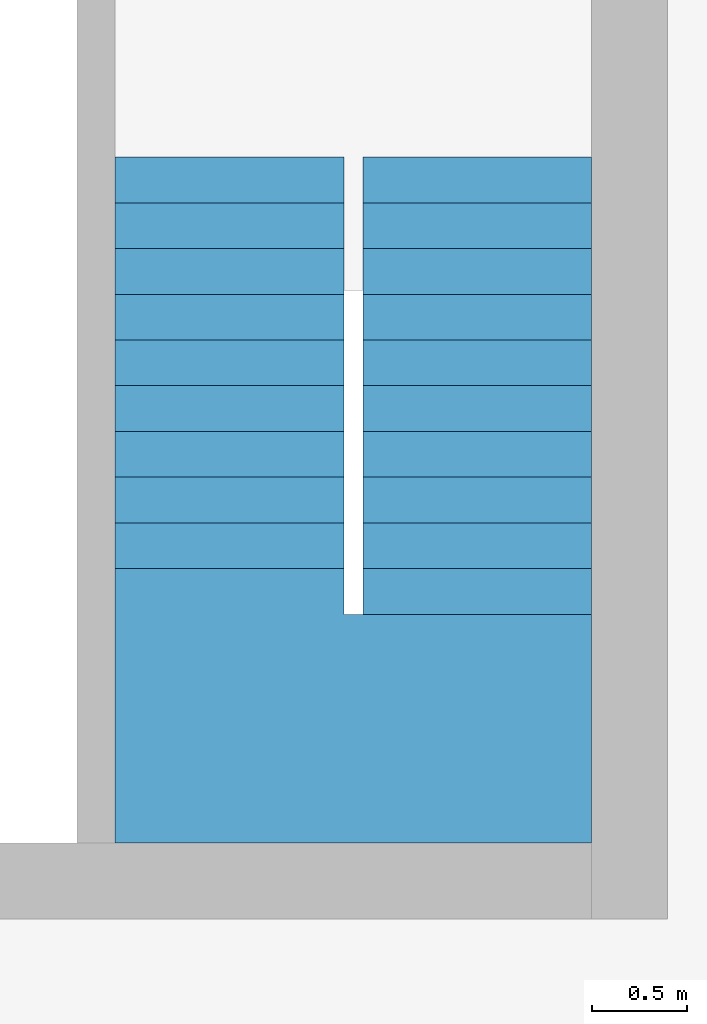
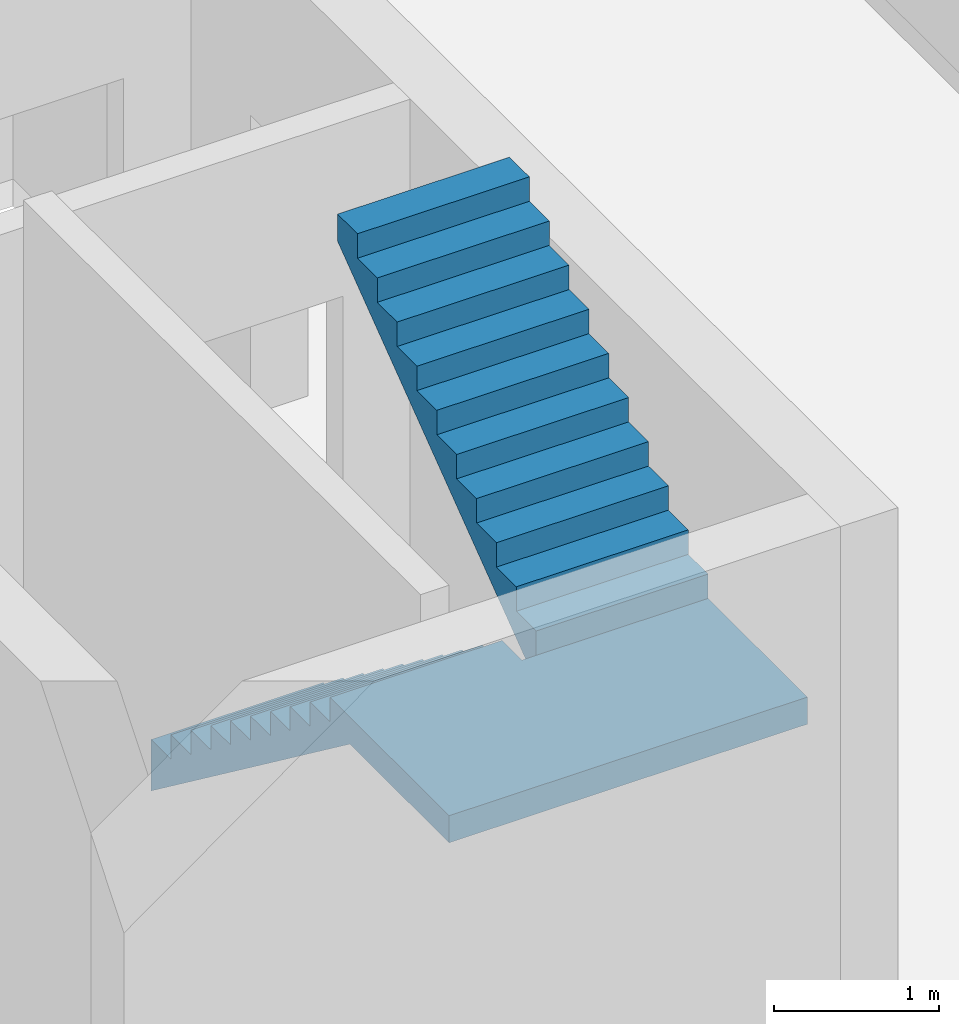
# One storey, part 2 of 4: 1 stair.
"""IFC2X3 building model written with IfcOpenShell, lengths in metres."""

from ifc_helpers import new_model, entity, si_unit, converted_unit, frame, origin, place, context, subcontext, project, spatial, faceted_brep, material, element, save


model = new_model("IFC2X3")

# Units and contexts
model_context = context("Model", 3, precision=1e-05, world=origin())
body_context = subcontext(model_context, "Body", "Model", "MODEL_VIEW")
ifc_project = project(units=[si_unit("LENGTHUNIT", "METRE"), si_unit("AREAUNIT", "SQUARE_METRE"), si_unit("VOLUMEUNIT", "CUBIC_METRE"), si_unit("MASSUNIT", "GRAM", prefix="KILO"), converted_unit("PLANEANGLEUNIT", "DEGREE", entity("IfcPlaneAngleMeasure", 0.0174532925199433), si_unit("PLANEANGLEUNIT", "RADIAN"), dimensions=[0, 0, 0, 0, 0, 0, 0])], contexts=[model_context])

# Site, building, storey
site_placement = place(None, origin())
site = spatial("IfcSite", under=ifc_project, at=site_placement, CompositionType="ELEMENT")
building_placement = place(site_placement, origin())
building = spatial("IfcBuilding", under=site, at=building_placement, CompositionType="ELEMENT")
storey_placement = place(building_placement, frame((0.0, 0.0, 4.9)))
storey = spatial("IfcBuildingStorey", under=building, at=storey_placement, Name="1. Obergeschoss", CompositionType="ELEMENT", Elevation=4.9)

# Stair
ifc_material = material(Name="FT_STB C45")
stair_placement = place(storey_placement, frame((22.5, 5.4, 0.0)))
element("IfcStair", 1, at=stair_placement, inside=storey, material=ifc_material, Name="II", ShapeType="NOTDEFINED", context=body_context, shape_type="Brep", body=[
    faceted_brep([(0.0, 3.6, 0.0), (0.0, 3.36001, 0.18), (1.2, 3.36001, 0.18), (1.2, 3.6, 0.0), (1.2, 3.6, 0.38), (1.2, 3.36001, 0.38), (0.0, 3.36001, 0.38), (0.0, 3.6, 0.38)], [[[0, 1, 2, 3]], [[4, 5, 6, 7]], [[3, 4, 7, 0]], [[0, 7, 6, 1]], [[1, 6, 5, 2]], [[2, 5, 4, 3]]], orient=[[False], [False], [False], [False], [False], [False]]),
    faceted_brep([(0.0, 3.36001, 0.18), (0.0, 3.12002, 0.36), (1.2, 3.12002, 0.36), (1.2, 3.36001, 0.18), (1.2, 3.36001, 0.56), (1.2, 3.12002, 0.56), (0.0, 3.12002, 0.56), (0.0, 3.36001, 0.56)], [[[0, 1, 2, 3]], [[4, 5, 6, 7]], [[3, 4, 7, 0]], [[0, 7, 6, 1]], [[1, 6, 5, 2]], [[2, 5, 4, 3]]], orient=[[False], [False], [False], [False], [False], [False]]),
    faceted_brep([(0.0, 3.12002, 0.36), (0.0, 2.88003, 0.54), (1.2, 2.88003, 0.54), (1.2, 3.12002, 0.36), (1.2, 3.12002, 0.74), (1.2, 2.88003, 0.74), (0.0, 2.88003, 0.74), (0.0, 3.12002, 0.74)], [[[0, 1, 2, 3]], [[4, 5, 6, 7]], [[3, 4, 7, 0]], [[0, 7, 6, 1]], [[1, 6, 5, 2]], [[2, 5, 4, 3]]], orient=[[False], [False], [False], [False], [False], [False]]),
    faceted_brep([(0.0, 2.88003, 0.54), (0.0, 2.64004, 0.72), (1.2, 2.64004, 0.72), (1.2, 2.88003, 0.54), (1.2, 2.88003, 0.92), (1.2, 2.64004, 0.92), (0.0, 2.64004, 0.92), (0.0, 2.88003, 0.92)], [[[0, 1, 2, 3]], [[4, 5, 6, 7]], [[3, 4, 7, 0]], [[0, 7, 6, 1]], [[1, 6, 5, 2]], [[2, 5, 4, 3]]], orient=[[False], [False], [False], [False], [False], [False]]),
    faceted_brep([(0.0, 2.64004, 0.72), (0.0, 2.40005, 0.9), (1.2, 2.40005, 0.9), (1.2, 2.64004, 0.72), (1.2, 2.64004, 1.1), (1.2, 2.40005, 1.1), (0.0, 2.40005, 1.1), (0.0, 2.64004, 1.1)], [[[0, 1, 2, 3]], [[4, 5, 6, 7]], [[3, 4, 7, 0]], [[0, 7, 6, 1]], [[1, 6, 5, 2]], [[2, 5, 4, 3]]], orient=[[False], [False], [False], [False], [False], [False]]),
    faceted_brep([(0.0, 2.40005, 0.9), (0.0, 2.16006, 1.08), (1.2, 2.16006, 1.08), (1.2, 2.40005, 0.9), (1.2, 2.40005, 1.28), (1.2, 2.16006, 1.28), (0.0, 2.16006, 1.28), (0.0, 2.40005, 1.28)], [[[0, 1, 2, 3]], [[4, 5, 6, 7]], [[3, 4, 7, 0]], [[0, 7, 6, 1]], [[1, 6, 5, 2]], [[2, 5, 4, 3]]], orient=[[False], [False], [False], [False], [False], [False]]),
    faceted_brep([(0.0, 2.16006, 1.08), (0.0, 1.92007, 1.26), (1.2, 1.92007, 1.26), (1.2, 2.16006, 1.08), (1.2, 2.16006, 1.46), (1.2, 1.92007, 1.46), (0.0, 1.92007, 1.46), (0.0, 2.16006, 1.46)], [[[0, 1, 2, 3]], [[4, 5, 6, 7]], [[3, 4, 7, 0]], [[0, 7, 6, 1]], [[1, 6, 5, 2]], [[2, 5, 4, 3]]], orient=[[False], [False], [False], [False], [False], [False]]),
    faceted_brep([(0.0, 1.92007, 1.26), (0.0, 1.68008, 1.44), (1.2, 1.68008, 1.44), (1.2, 1.92007, 1.26), (1.2, 1.92007, 1.64), (1.2, 1.68008, 1.64), (0.0, 1.68008, 1.64), (0.0, 1.92007, 1.64)], [[[0, 1, 2, 3]], [[4, 5, 6, 7]], [[3, 4, 7, 0]], [[0, 7, 6, 1]], [[1, 6, 5, 2]], [[2, 5, 4, 3]]], orient=[[False], [False], [False], [False], [False], [False]]),
    faceted_brep([(0.0, 1.68008, 1.44), (0.0, 1.44009, 1.62), (1.2, 1.44009, 1.62), (1.2, 1.68008, 1.44), (1.2, 1.68008, 1.82), (1.2, 1.44009, 1.82), (0.0, 1.44009, 1.82), (0.0, 1.68008, 1.82)], [[[0, 1, 2, 3]], [[4, 5, 6, 7]], [[3, 4, 7, 0]], [[0, 7, 6, 1]], [[1, 6, 5, 2]], [[2, 5, 4, 3]]], orient=[[False], [False], [False], [False], [False], [False]]),
    faceted_brep([(0.0, 1.44009, 1.62), (0.0, 1.2001, 1.8), (1.2, 1.2001, 1.8), (1.2, 1.44009, 1.62), (1.2, 1.44009, 2.0), (1.2, 1.2001, 2.0), (0.0, 1.2001, 2.0), (0.0, 1.44009, 2.0)], [[[0, 1, 2, 3]], [[4, 5, 6, 7]], [[3, 4, 7, 0]], [[0, 7, 6, 1]], [[1, 6, 5, 2]], [[2, 5, 4, 3]]], orient=[[False], [False], [False], [False], [False], [False]]),
    faceted_brep([(1.2, 1.2001, 1.8), (0.0, 1.2001, 1.8), (0.0, 0.0, 1.8), (1.201, 0.0, 1.8), (1.201, 1.2, 1.8), (1.2, 1.2, 1.8), (0.0, 1.2001, 2.0), (1.2, 1.2001, 2.0), (1.2, 1.2, 2.0), (1.201, 1.2, 2.0), (1.201, 0.0, 2.0), (0.0, 0.0, 2.0)], [[[0, 1, 2, 3, 4, 5]], [[6, 7, 8, 9, 10, 11]], [[1, 0, 7, 6]], [[2, 1, 6, 11]], [[3, 2, 11, 10]], [[4, 3, 10, 9]], [[5, 4, 9, 8]], [[0, 5, 8, 7]]], orient=[[False], [False], [False], [False], [False], [False], [False], [False]]),
    faceted_brep([(2.5, 1.2001, 1.8), (2.5, 1.44009, 1.98), (1.3, 1.44009, 1.98), (1.3, 1.2001, 1.8), (1.3, 1.2001, 2.18), (1.3, 1.44009, 2.18), (2.5, 1.44009, 2.18), (2.5, 1.2001, 2.18)], [[[0, 1, 2, 3]], [[4, 5, 6, 7]], [[3, 4, 7, 0]], [[0, 7, 6, 1]], [[1, 6, 5, 2]], [[2, 5, 4, 3]]], orient=[[False], [False], [False], [False], [False], [False]]),
    faceted_brep([(2.5, 1.44009, 1.98), (2.5, 1.68008, 2.16), (1.3, 1.68008, 2.16), (1.3, 1.44009, 1.98), (1.3, 1.44009, 2.36), (1.3, 1.68008, 2.36), (2.5, 1.68008, 2.36), (2.5, 1.44009, 2.36)], [[[0, 1, 2, 3]], [[4, 5, 6, 7]], [[3, 4, 7, 0]], [[0, 7, 6, 1]], [[1, 6, 5, 2]], [[2, 5, 4, 3]]], orient=[[False], [False], [False], [False], [False], [False]]),
    faceted_brep([(2.5, 1.68008, 2.16), (2.5, 1.92007, 2.34), (1.3, 1.92007, 2.34), (1.3, 1.68008, 2.16), (1.3, 1.68008, 2.54), (1.3, 1.92007, 2.54), (2.5, 1.92007, 2.54), (2.5, 1.68008, 2.54)], [[[0, 1, 2, 3]], [[4, 5, 6, 7]], [[3, 4, 7, 0]], [[0, 7, 6, 1]], [[1, 6, 5, 2]], [[2, 5, 4, 3]]], orient=[[False], [False], [False], [False], [False], [False]]),
    faceted_brep([(2.5, 1.92007, 2.34), (2.5, 2.16006, 2.52), (1.3, 2.16006, 2.52), (1.3, 1.92007, 2.34), (1.3, 1.92007, 2.72), (1.3, 2.16006, 2.72), (2.5, 2.16006, 2.72), (2.5, 1.92007, 2.72)], [[[0, 1, 2, 3]], [[4, 5, 6, 7]], [[3, 4, 7, 0]], [[0, 7, 6, 1]], [[1, 6, 5, 2]], [[2, 5, 4, 3]]], orient=[[False], [False], [False], [False], [False], [False]]),
    faceted_brep([(2.5, 2.40005, 2.7), (2.5, 2.64004, 2.88), (1.3, 2.64004, 2.88), (1.3, 2.40005, 2.7), (1.3, 2.40005, 3.08), (1.3, 2.64004, 3.08), (2.5, 2.64004, 3.08), (2.5, 2.40005, 3.08)], [[[0, 1, 2, 3]], [[4, 5, 6, 7]], [[3, 4, 7, 0]], [[0, 7, 6, 1]], [[1, 6, 5, 2]], [[2, 5, 4, 3]]], orient=[[False], [False], [False], [False], [False], [False]]),
    faceted_brep([(2.5, 2.64004, 2.88), (2.5, 2.88003, 3.06), (1.3, 2.88003, 3.06), (1.3, 2.64004, 2.88), (1.3, 2.64004, 3.26), (1.3, 2.88003, 3.26), (2.5, 2.88003, 3.26), (2.5, 2.64004, 3.26)], [[[0, 1, 2, 3]], [[4, 5, 6, 7]], [[3, 4, 7, 0]], [[0, 7, 6, 1]], [[1, 6, 5, 2]], [[2, 5, 4, 3]]], orient=[[False], [False], [False], [False], [False], [False]]),
    faceted_brep([(2.5, 2.88003, 3.06), (2.5, 3.12002, 3.24), (1.3, 3.12002, 3.24), (1.3, 2.88003, 3.06), (1.3, 2.88003, 3.44), (1.3, 3.12002, 3.44), (2.5, 3.12002, 3.44), (2.5, 2.88003, 3.44)], [[[0, 1, 2, 3]], [[4, 5, 6, 7]], [[3, 4, 7, 0]], [[0, 7, 6, 1]], [[1, 6, 5, 2]], [[2, 5, 4, 3]]], orient=[[False], [False], [False], [False], [False], [False]]),
    faceted_brep([(2.5, 3.12002, 3.24), (2.5, 3.36001, 3.42), (1.3, 3.36001, 3.42), (1.3, 3.12002, 3.24), (1.3, 3.12002, 3.62), (1.3, 3.36001, 3.62), (2.5, 3.36001, 3.62), (2.5, 3.12002, 3.62)], [[[0, 1, 2, 3]], [[4, 5, 6, 7]], [[3, 4, 7, 0]], [[0, 7, 6, 1]], [[1, 6, 5, 2]], [[2, 5, 4, 3]]], orient=[[False], [False], [False], [False], [False], [False]]),
    faceted_brep([(1.201, 1.2, 1.8), (1.201, 0.0, 1.8), (2.5, 0.0, 1.8), (2.5, 1.2001, 1.8), (1.3, 1.2001, 1.8), (1.3, 1.2, 1.8), (1.201, 0.0, 2.0), (1.201, 1.2, 2.0), (1.3, 1.2, 2.0), (1.3, 1.2001, 2.0), (2.5, 1.2001, 2.0), (2.5, 0.0, 2.0)], [[[0, 1, 2, 3, 4, 5]], [[6, 7, 8, 9, 10, 11]], [[1, 0, 7, 6]], [[2, 1, 6, 11]], [[3, 2, 11, 10]], [[4, 3, 10, 9]], [[5, 4, 9, 8]], [[0, 5, 8, 7]]], orient=[[False], [False], [False], [False], [False], [False], [False], [False]]),
    faceted_brep([(2.5, 2.16006, 2.52), (2.5, 2.40005, 2.7), (1.3, 2.40005, 2.7), (1.3, 2.16006, 2.52), (1.3, 2.16006, 2.9), (1.3, 2.40005, 2.9), (2.5, 2.40005, 2.9), (2.5, 2.16006, 2.9)], [[[0, 1, 2, 3]], [[4, 5, 6, 7]], [[3, 4, 7, 0]], [[0, 7, 6, 1]], [[1, 6, 5, 2]], [[2, 5, 4, 3]]], orient=[[False], [False], [False], [False], [False], [False]]),
    faceted_brep([(2.5, 3.36001, 3.42), (2.5, 3.6, 3.6), (1.3, 3.6, 3.6), (1.3, 3.36001, 3.42), (1.3, 3.36001, 3.8), (1.3, 3.6, 3.8), (2.5, 3.6, 3.8), (2.5, 3.36001, 3.8)], [[[0, 1, 2, 3]], [[4, 5, 6, 7]], [[3, 4, 7, 0]], [[0, 7, 6, 1]], [[1, 6, 5, 2]], [[2, 5, 4, 3]]], orient=[[False], [False], [False], [False], [False], [False]]),
])

save(model, "model.ifc")
